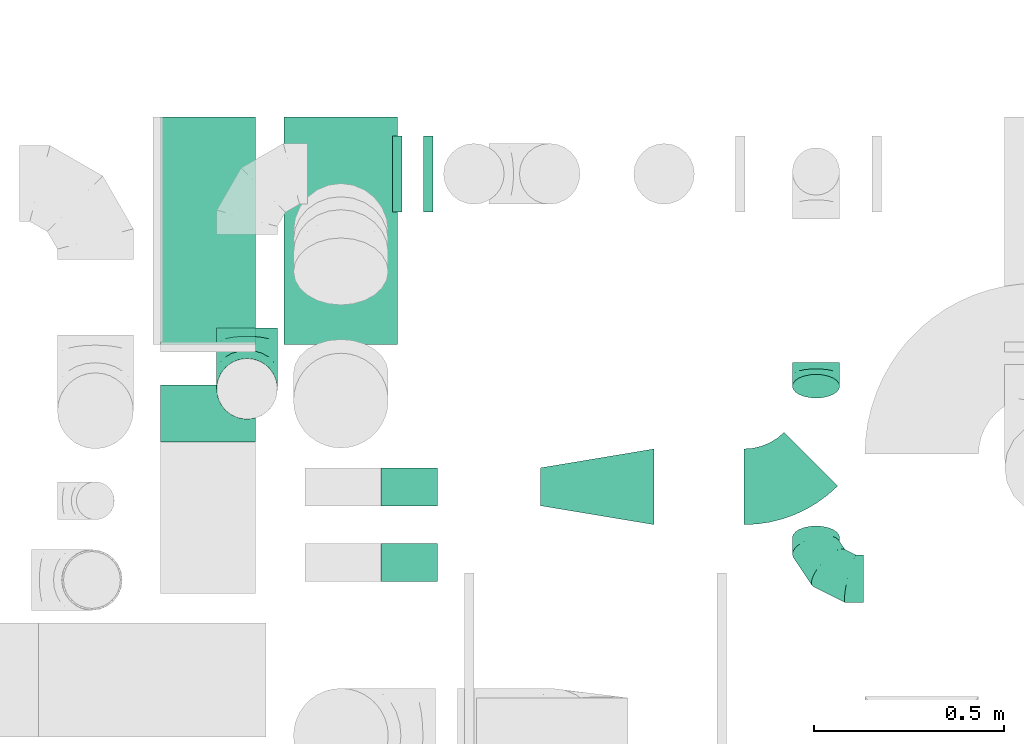
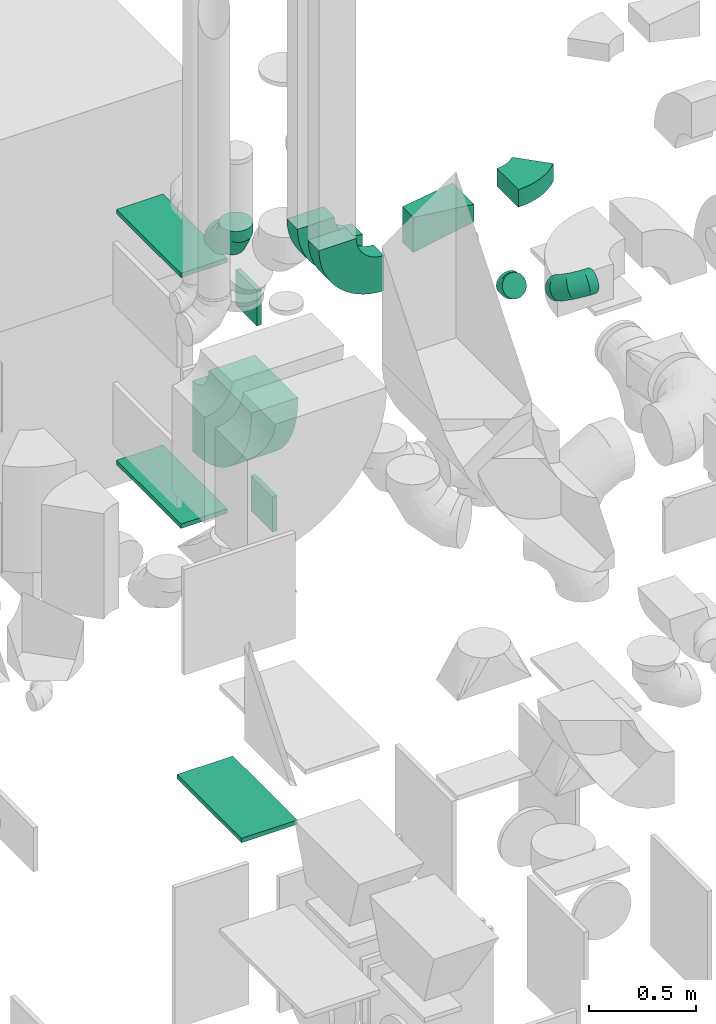
# One storey, part 28 of 59: 13 flow fittings.
"""IFC2X3 building model written with IfcOpenShell, lengths in millimetres."""

from ifc_helpers import new_model, entity, si_unit, converted_unit, derived_unit, direction, frame, frame_2d, origin, origin_2d_with_axis, place, context, subcontext, project, spatial, polyline, circle_curve, parameter, trimmed, segment, composite_curve, rectangle, outline, extrude, faceted_brep, source, transform, mapped, material, type_object, type_shapes, element, save


model = new_model("IFC2X3")

# Units and contexts
model_context = context("Model", 3, precision=0.01, world=origin(), true_north=direction((6.12303176911189e-17, 1.0)))
body_context = subcontext(model_context, "Body", "Model", "MODEL_VIEW")
ifc_project = project(units=[si_unit("LENGTHUNIT", "METRE", prefix="MILLI"), si_unit("AREAUNIT", "SQUARE_METRE"), si_unit("VOLUMEUNIT", "CUBIC_METRE"), converted_unit("PLANEANGLEUNIT", "DEGREE", entity("IfcRatioMeasure", 0.0174532925199433), si_unit("PLANEANGLEUNIT", "RADIAN"), dimensions=[0, 0, 0, 0, 0, 0, 0]), si_unit("MASSUNIT", "GRAM", prefix="KILO"), derived_unit("MASSDENSITYUNIT", [(si_unit("MASSUNIT", "GRAM", prefix="KILO"), 1), (si_unit("LENGTHUNIT", "METRE"), -3)]), derived_unit("MOMENTOFINERTIAUNIT", [(si_unit("LENGTHUNIT", "METRE"), 4)]), si_unit("TIMEUNIT", "SECOND"), si_unit("FREQUENCYUNIT", "HERTZ"), si_unit("THERMODYNAMICTEMPERATUREUNIT", "DEGREE_CELSIUS"), derived_unit("THERMALTRANSMITTANCEUNIT", [(si_unit("MASSUNIT", "GRAM", prefix="KILO"), 1), (si_unit("THERMODYNAMICTEMPERATUREUNIT", "KELVIN"), -1), (si_unit("TIMEUNIT", "SECOND"), -3)]), derived_unit("VOLUMETRICFLOWRATEUNIT", [(si_unit("LENGTHUNIT", "METRE"), 3), (si_unit("TIMEUNIT", "SECOND"), -1)]), derived_unit("MASSFLOWRATEUNIT", [(si_unit("MASSUNIT", "GRAM", prefix="KILO"), 1), (si_unit("TIMEUNIT", "SECOND"), -1)]), derived_unit("ROTATIONALFREQUENCYUNIT", [(si_unit("TIMEUNIT", "SECOND"), -1)]), si_unit("ELECTRICCURRENTUNIT", "AMPERE"), si_unit("ELECTRICVOLTAGEUNIT", "VOLT"), si_unit("POWERUNIT", "WATT"), si_unit("FORCEUNIT", "NEWTON", prefix="KILO"), si_unit("ILLUMINANCEUNIT", "LUX"), si_unit("LUMINOUSFLUXUNIT", "LUMEN"), si_unit("LUMINOUSINTENSITYUNIT", "CANDELA"), derived_unit("USERDEFINED", [(si_unit("MASSUNIT", "GRAM", prefix="KILO"), -1), (si_unit("LENGTHUNIT", "METRE"), -2), (si_unit("TIMEUNIT", "SECOND"), 3), (si_unit("LUMINOUSFLUXUNIT", "LUMEN"), 1)]), derived_unit("LINEARVELOCITYUNIT", [(si_unit("LENGTHUNIT", "METRE"), 1), (si_unit("TIMEUNIT", "SECOND"), -1)]), si_unit("PRESSUREUNIT", "PASCAL"), derived_unit("USERDEFINED", [(si_unit("LENGTHUNIT", "METRE"), -2), (si_unit("MASSUNIT", "GRAM", prefix="KILO"), 1), (si_unit("TIMEUNIT", "SECOND"), -2)]), derived_unit("LINEARFORCEUNIT", [(si_unit("MASSUNIT", "GRAM", prefix="KILO"), 1), (si_unit("LENGTHUNIT", "METRE"), 1), (si_unit("TIMEUNIT", "SECOND"), -2), (si_unit("LENGTHUNIT", "METRE"), -1)]), derived_unit("PLANARFORCEUNIT", [(si_unit("MASSUNIT", "GRAM", prefix="KILO"), 1), (si_unit("LENGTHUNIT", "METRE"), 1), (si_unit("TIMEUNIT", "SECOND"), -2), (si_unit("LENGTHUNIT", "METRE"), -2)])], contexts=[model_context])

# Site, building, storey
site_placement = place(None, origin())
site = spatial("IfcSite", under=ifc_project, at=site_placement, CompositionType="ELEMENT")
building_placement = place(site_placement, origin())
building = spatial("IfcBuilding", under=site, at=building_placement, CompositionType="ELEMENT")
storey_placement = place(building_placement, frame((0.0, 0.0, 28200.0)))
storey = spatial("IfcBuildingStorey", under=building, at=storey_placement, CompositionType="ELEMENT", Elevation=28200.0)

# Flow fittings
ifc_material = material()
duct_fitting_type_1 = type_object("IfcDuctFittingType", PredefinedType="NOTDEFINED", material=ifc_material)
shared_shape_1 = source(origin(), body_context, "Body", "SweptSolid", [
    extrude(rectangle(XDim=24.9999999999999, YDim=600.0, at=origin_2d_with_axis()), frame((12.5, 0.0, -150.0)), (0.0, 0.0, 1.0), 300.0),
])
type_shapes(duct_fitting_type_1, [shared_shape_1])
flow_fitting_1_placement = place(storey_placement, frame((49017.58, 12874.75, 200.0), z_axis=(1.0, 0.0, 0.0), x_axis=(0.0, 0.0, -1.0)))
element("IfcFlowFitting", 1, at=flow_fitting_1_placement, inside=storey, type_object=duct_fitting_type_1, material=ifc_material, context=body_context, shape_type="MappedRepresentation", body=[
    mapped(shared_shape_1, transform((0.0, 0.0, 0.0), scale=1.0)),
])
duct_fitting_type_2 = type_object("IfcDuctFittingType", PredefinedType="NOTDEFINED", material=ifc_material)
shared_shape_2 = source(origin(), body_context, "Body", "SweptSolid", [
    extrude(rectangle(XDim=24.9999999999999, YDim=200.0, at=origin_2d_with_axis()), frame((12.5, 0.0, -100.0)), (0.0, 0.0, 1.0), 200.0),
])
type_shapes(duct_fitting_type_2, [shared_shape_2])
for number, where, z_axis, x_axis in (
    (2, (49260.78, 13024.99, 1699.32), (0.0, 0.0, 1.0), (-1.0, 0.0, 0.0)),
    (3, (49178.28, 13024.99, 2899.32), (0.0, 0.0, 1.0), (-1.0, 0.0, 0.0)),
):
    element("IfcFlowFitting", number, at=place(storey_placement, frame(where, z_axis=z_axis, x_axis=x_axis)), inside=storey, type_object=duct_fitting_type_2, material=ifc_material, context=body_context, shape_type="MappedRepresentation", body=[
        mapped(shared_shape_2, transform((0.0, 0.0, 0.0), scale=1.0)),
    ])
duct_fitting_type_3 = type_object("IfcDuctFittingType", PredefinedType="NOTDEFINED", material=ifc_material)
shared_shape_3 = source(origin(), body_context, "Body", "SweptSolid", [
    extrude(rectangle(XDim=24.9999999999999, YDim=600.0, at=origin_2d_with_axis()), frame((12.5, 0.0, -125.0)), (0.0, 0.0, 1.0), 250.0),
])
type_shapes(duct_fitting_type_3, [shared_shape_3])
for number, where, z_axis, x_axis in (
    (4, (48667.04, 12874.75, 2100.0), (1.0, 0.0, 0.0), (0.0, 0.0, -1.0)),
    (5, (48667.04, 12874.75, 3500.0), (1.0, 0.0, 0.0), (0.0, 0.0, 1.0)),
):
    element("IfcFlowFitting", number, at=place(storey_placement, frame(where, z_axis=z_axis, x_axis=x_axis)), inside=storey, type_object=duct_fitting_type_3, material=ifc_material, context=body_context, shape_type="MappedRepresentation", body=[
        mapped(shared_shape_3, transform((0.0, 0.0, 0.0), scale=1.0)),
    ])
duct_fitting_type_4 = type_object("IfcDuctFittingType", PredefinedType="NOTDEFINED", material=ifc_material)
shared_shape_4 = source(origin(), body_context, "Body", "Brep", [
    faceted_brep([(-160.0, 0.0, -80.0), (-160.0, -20.71, -77.27), (-160.0, -40.0, -69.28), (-160.0, -56.57, -56.57), (-160.0, -69.28, -40.0), (-160.0, -77.27, -20.71), (-160.0, -80.0, 0.0), (-160.0, -77.27, 20.71), (-160.0, -69.28, 40.0), (-160.0, -56.57, 56.57), (-160.0, -40.0, 69.28), (-160.0, -20.71, 77.27), (-160.0, 0.0, 80.0), (-160.0, 20.71, 77.27), (-160.0, 40.0, 69.28), (-160.0, 56.57, 56.57), (-160.0, 69.28, 40.0), (-160.0, 77.27, 20.71), (-160.0, 80.0, 0.0), (-160.0, 77.27, -20.71), (-160.0, 69.28, -40.0), (-160.0, 56.57, -56.57), (-160.0, 40.0, -69.28), (-160.0, 20.71, -77.27), (-122.68, 20.71, 77.27), (-127.85, 40.0, 69.28), (-117.13, 0.0, 80.0), (-132.29, 56.57, 56.57), (-137.83, 77.27, 20.71), (-138.56, 80.0, 0.0), (-135.69, 69.28, 40.0), (-135.69, 69.28, -40.0), (-132.29, 56.57, -56.57), (-137.83, 77.27, -20.71), (-122.68, 20.71, -77.27), (-117.13, 0.0, -80.0), (-127.85, 40.0, -69.28), (-111.58, -20.71, -77.27), (-106.41, -40.0, -69.28), (-101.97, -56.57, -56.57), (-98.56, -69.28, -40.0), (-96.42, -77.27, -20.71), (-95.69, -80.0, 0.0), (-96.42, -77.27, 20.71), (-98.56, -69.28, 40.0), (-101.97, -56.57, 56.57), (-106.41, -40.0, 69.28), (-111.58, -20.71, 77.27), (-58.03, 58.03, 77.27), (-72.15, 72.15, 69.28), (-42.87, 42.87, 80.0), (-84.28, 84.28, 56.57), (-93.59, 93.59, 40.0), (-99.44, 99.44, 20.71), (-101.44, 101.44, 0.0), (-99.44, 99.44, -20.71), (-93.59, 93.59, -40.0), (-84.28, 84.28, -56.57), (-58.03, 58.03, -77.27), (-42.87, 42.87, -80.0), (-72.15, 72.15, -69.28), (-27.71, 27.71, -77.27), (-13.59, 13.59, -69.28), (-1.46, 1.46, -56.57), (7.85, -7.85, -40.0), (13.7, -13.7, -20.71), (15.69, -15.69, 0.0), (13.7, -13.7, 20.71), (7.85, -7.85, 40.0), (-1.46, 1.46, 56.57), (-13.59, 13.59, 69.28), (-27.71, 27.71, 77.27), (-20.71, 122.68, 77.27), (-40.0, 127.85, 69.28), (0.0, 117.13, 80.0), (-56.57, 132.29, 56.57), (-69.28, 135.69, 40.0), (-77.27, 137.83, 20.71), (-80.0, 138.56, 0.0), (-77.27, 137.83, -20.71), (-69.28, 135.69, -40.0), (-56.57, 132.29, -56.57), (-20.71, 122.68, -77.27), (0.0, 117.13, -80.0), (-40.0, 127.85, -69.28), (20.71, 111.58, -77.27), (40.0, 106.41, -69.28), (56.57, 101.97, -56.57), (69.28, 98.56, -40.0), (77.27, 96.42, -20.71), (80.0, 95.69, 0.0), (77.27, 96.42, 20.71), (69.28, 98.56, 40.0), (56.57, 101.97, 56.57), (40.0, 106.41, 69.28), (20.71, 111.58, 77.27), (-20.71, 160.0, -77.27), (-40.0, 160.0, -69.28), (-56.57, 160.0, -56.57), (-69.28, 160.0, -40.0), (-77.27, 160.0, -20.71), (-80.0, 160.0, 0.0), (-77.27, 160.0, 20.71), (-69.28, 160.0, 40.0), (-56.57, 160.0, 56.57), (-40.0, 160.0, 69.28), (-20.71, 160.0, 77.27), (0.0, 160.0, 80.0), (20.71, 160.0, 77.27), (40.0, 160.0, 69.28), (56.57, 160.0, 56.57), (69.28, 160.0, 40.0), (77.27, 160.0, 20.71), (80.0, 160.0, 0.0), (77.27, 160.0, -20.71), (69.28, 160.0, -40.0), (56.57, 160.0, -56.57), (40.0, 160.0, -69.28), (20.71, 160.0, -77.27), (0.0, 160.0, -80.0)], [[[0, 1, 2, 3, 4, 5, 6, 7, 8, 9, 10, 11, 12, 13, 14, 15, 16, 17, 18, 19, 20, 21, 22, 23]], [[24, 25, 14, 13]], [[26, 24, 13, 12]], [[14, 25, 27, 15]], [[28, 29, 18, 17]], [[30, 28, 17, 16]], [[15, 27, 30, 16]], [[20, 31, 32, 21]], [[33, 31, 20, 19]], [[18, 29, 33, 19]], [[34, 35, 0, 23]], [[36, 34, 23, 22]], [[32, 36, 22, 21]], [[1, 0, 35, 37]], [[2, 1, 37, 38]], [[3, 2, 38, 39]], [[5, 4, 40, 41]], [[6, 5, 41, 42]], [[39, 40, 4, 3]], [[6, 42, 43, 7]], [[7, 43, 44, 8]], [[8, 44, 45, 9]], [[9, 45, 46, 10]], [[10, 46, 47, 11]], [[26, 12, 11, 47]], [[48, 49, 25, 24]], [[50, 48, 24, 26]], [[27, 25, 49, 51]], [[52, 53, 28, 30]], [[51, 52, 30, 27]], [[29, 28, 53, 54]], [[55, 56, 31, 33]], [[54, 55, 33, 29]], [[32, 31, 56, 57]], [[58, 59, 35, 34]], [[60, 58, 34, 36]], [[57, 60, 36, 32]], [[37, 35, 59, 61]], [[38, 37, 61, 62]], [[39, 38, 62, 63]], [[41, 40, 64, 65]], [[42, 41, 65, 66]], [[63, 64, 40, 39]], [[43, 42, 66, 67]], [[44, 43, 67, 68]], [[68, 69, 45, 44]], [[46, 45, 69, 70]], [[47, 46, 70, 71]], [[26, 47, 71, 50]], [[72, 73, 49, 48]], [[74, 72, 48, 50]], [[51, 49, 73, 75]], [[76, 77, 53, 52]], [[75, 76, 52, 51]], [[54, 53, 77, 78]], [[79, 80, 56, 55]], [[78, 79, 55, 54]], [[57, 56, 80, 81]], [[82, 83, 59, 58]], [[84, 82, 58, 60]], [[81, 84, 60, 57]], [[61, 59, 83, 85]], [[62, 61, 85, 86]], [[63, 62, 86, 87]], [[65, 64, 88, 89]], [[66, 65, 89, 90]], [[87, 88, 64, 63]], [[67, 66, 90, 91]], [[68, 67, 91, 92]], [[92, 93, 69, 68]], [[70, 69, 93, 94]], [[71, 70, 94, 95]], [[50, 71, 95, 74]], [[96, 97, 98, 99, 100, 101, 102, 103, 104, 105, 106, 107, 108, 109, 110, 111, 112, 113, 114, 115, 116, 117, 118, 119]], [[72, 74, 107, 106]], [[73, 72, 106, 105]], [[75, 73, 105, 104]], [[77, 76, 103, 102]], [[78, 77, 102, 101]], [[75, 104, 103, 76]], [[78, 101, 100, 79]], [[79, 100, 99, 80]], [[80, 99, 98, 81]], [[84, 97, 96, 82]], [[82, 96, 119, 83]], [[84, 81, 98, 97]], [[118, 117, 86, 85]], [[119, 118, 85, 83]], [[116, 87, 86, 117]], [[88, 115, 114, 89]], [[89, 114, 113, 90]], [[115, 88, 87, 116]], [[112, 111, 92, 91]], [[113, 112, 91, 90]], [[111, 110, 93, 92]], [[95, 94, 109, 108]], [[74, 95, 108, 107]], [[110, 109, 94, 93]]]),
])
type_shapes(duct_fitting_type_4, [shared_shape_4])
flow_fitting_2_placement = place(storey_placement, frame((48770.09, 12457.98, 3650.0), z_axis=(1.0, 0.0, 0.0), x_axis=(0.0, 0.0, -1.0)))
element("IfcFlowFitting", 6, at=flow_fitting_2_placement, inside=storey, type_object=duct_fitting_type_4, material=ifc_material, context=body_context, shape_type="MappedRepresentation", body=[
    mapped(shared_shape_4, transform((0.0, 0.0, 0.0), scale=1.0)),
])
duct_fitting_type_5 = type_object("IfcDuctFittingType", PredefinedType="NOTDEFINED", material=ifc_material)
shared_shape_5 = source(origin(), body_context, "Body", "Brep", [
    faceted_brep([(-125.0, 0.0, -62.5), (-125.0, -16.18, -60.37), (-125.0, -31.25, -54.13), (-125.0, -44.19, -44.19), (-125.0, -54.13, -31.25), (-125.0, -60.37, -16.18), (-125.0, -62.5, 0.0), (-125.0, -60.37, 16.18), (-125.0, -54.13, 31.25), (-125.0, -44.19, 44.19), (-125.0, -31.25, 54.13), (-125.0, -16.18, 60.37), (-125.0, 0.0, 62.5), (-125.0, 16.18, 60.37), (-125.0, 31.25, 54.13), (-125.0, 44.19, 44.19), (-125.0, 54.13, 31.25), (-125.0, 60.37, 16.18), (-125.0, 62.5, 0.0), (-125.0, 60.37, -16.18), (-125.0, 54.13, -31.25), (-125.0, 44.19, -44.19), (-125.0, 31.25, -54.13), (-125.0, 16.18, -60.37), (-95.84, 16.18, 60.37), (-99.88, 31.25, 54.13), (-91.51, 0.0, 62.5), (-103.35, 44.19, 44.19), (-107.68, 60.37, 16.18), (-108.25, 62.5, 0.0), (-106.01, 54.13, 31.25), (-106.01, 54.13, -31.25), (-103.35, 44.19, -44.19), (-107.68, 60.37, -16.18), (-95.84, 16.18, -60.37), (-91.51, 0.0, -62.5), (-99.88, 31.25, -54.13), (-87.17, -16.18, -60.37), (-83.13, -31.25, -54.13), (-79.66, -44.19, -44.19), (-77.0, -54.13, -31.25), (-75.33, -60.37, -16.18), (-74.76, -62.5, 0.0), (-75.33, -60.37, 16.18), (-77.0, -54.13, 31.25), (-79.66, -44.19, 44.19), (-83.13, -31.25, 54.13), (-87.17, -16.18, 60.37), (-45.34, 45.34, 60.37), (-56.37, 56.37, 54.13), (-33.49, 33.49, 62.5), (-65.85, 65.85, 44.19), (-73.12, 73.12, 31.25), (-77.69, 77.69, 16.18), (-79.25, 79.25, 0.0), (-77.69, 77.69, -16.18), (-73.12, 73.12, -31.25), (-65.85, 65.85, -44.19), (-45.34, 45.34, -60.37), (-33.49, 33.49, -62.5), (-56.37, 56.37, -54.13), (-21.65, 21.65, -60.37), (-10.62, 10.62, -54.13), (-1.14, 1.14, -44.19), (6.13, -6.13, -31.25), (10.7, -10.7, -16.18), (12.26, -12.26, 0.0), (10.7, -10.7, 16.18), (6.13, -6.13, 31.25), (-1.14, 1.14, 44.19), (-10.62, 10.62, 54.13), (-21.65, 21.65, 60.37), (-16.18, 95.84, 60.37), (-31.25, 99.88, 54.13), (0.0, 91.51, 62.5), (-44.19, 103.35, 44.19), (-54.13, 106.01, 31.25), (-60.37, 107.68, 16.18), (-62.5, 108.25, 0.0), (-60.37, 107.68, -16.18), (-54.13, 106.01, -31.25), (-44.19, 103.35, -44.19), (-16.18, 95.84, -60.37), (0.0, 91.51, -62.5), (-31.25, 99.88, -54.13), (16.18, 87.17, -60.37), (31.25, 83.13, -54.13), (44.19, 79.66, -44.19), (54.13, 77.0, -31.25), (60.37, 75.33, -16.18), (62.5, 74.76, 0.0), (60.37, 75.33, 16.18), (54.13, 77.0, 31.25), (44.19, 79.66, 44.19), (31.25, 83.13, 54.13), (16.18, 87.17, 60.37), (-16.18, 125.0, -60.37), (-31.25, 125.0, -54.13), (-44.19, 125.0, -44.19), (-54.13, 125.0, -31.25), (-60.37, 125.0, -16.18), (-62.5, 125.0, 0.0), (-60.37, 125.0, 16.18), (-54.13, 125.0, 31.25), (-44.19, 125.0, 44.19), (-31.25, 125.0, 54.13), (-16.18, 125.0, 60.37), (0.0, 125.0, 62.5), (16.18, 125.0, 60.37), (31.25, 125.0, 54.13), (44.19, 125.0, 44.19), (54.13, 125.0, 31.25), (60.37, 125.0, 16.18), (62.5, 125.0, 0.0), (60.37, 125.0, -16.18), (54.13, 125.0, -31.25), (44.19, 125.0, -44.19), (31.25, 125.0, -54.13), (16.18, 125.0, -60.37), (0.0, 125.0, -62.5)], [[[0, 1, 2, 3, 4, 5, 6, 7, 8, 9, 10, 11, 12, 13, 14, 15, 16, 17, 18, 19, 20, 21, 22, 23]], [[24, 25, 14, 13]], [[26, 24, 13, 12]], [[14, 25, 27, 15]], [[28, 29, 18, 17]], [[30, 28, 17, 16]], [[15, 27, 30, 16]], [[20, 31, 32, 21]], [[33, 31, 20, 19]], [[18, 29, 33, 19]], [[34, 35, 0, 23]], [[36, 34, 23, 22]], [[21, 32, 36, 22]], [[1, 0, 35, 37]], [[2, 1, 37, 38]], [[38, 39, 3, 2]], [[5, 4, 40, 41]], [[6, 5, 41, 42]], [[39, 40, 4, 3]], [[6, 42, 43, 7]], [[7, 43, 44, 8]], [[45, 9, 8, 44]], [[9, 45, 46, 10]], [[10, 46, 47, 11]], [[26, 12, 11, 47]], [[48, 49, 25, 24]], [[50, 48, 24, 26]], [[27, 25, 49, 51]], [[52, 53, 28, 30]], [[51, 52, 30, 27]], [[29, 28, 53, 54]], [[55, 56, 31, 33]], [[54, 55, 33, 29]], [[57, 32, 31, 56]], [[58, 59, 35, 34]], [[60, 58, 34, 36]], [[57, 60, 36, 32]], [[37, 35, 59, 61]], [[38, 37, 61, 62]], [[39, 38, 62, 63]], [[41, 40, 64, 65]], [[42, 41, 65, 66]], [[63, 64, 40, 39]], [[43, 42, 66, 67]], [[44, 43, 67, 68]], [[68, 69, 45, 44]], [[46, 45, 69, 70]], [[47, 46, 70, 71]], [[26, 47, 71, 50]], [[72, 73, 49, 48]], [[74, 72, 48, 50]], [[51, 49, 73, 75]], [[76, 77, 53, 52]], [[75, 76, 52, 51]], [[54, 53, 77, 78]], [[79, 80, 56, 55]], [[78, 79, 55, 54]], [[81, 57, 56, 80]], [[82, 83, 59, 58]], [[84, 82, 58, 60]], [[81, 84, 60, 57]], [[61, 59, 83, 85]], [[62, 61, 85, 86]], [[63, 62, 86, 87]], [[65, 64, 88, 89]], [[66, 65, 89, 90]], [[87, 88, 64, 63]], [[67, 66, 90, 91]], [[68, 67, 91, 92]], [[92, 93, 69, 68]], [[70, 69, 93, 94]], [[71, 70, 94, 95]], [[50, 71, 95, 74]], [[96, 97, 98, 99, 100, 101, 102, 103, 104, 105, 106, 107, 108, 109, 110, 111, 112, 113, 114, 115, 116, 117, 118, 119]], [[72, 74, 107, 106]], [[73, 72, 106, 105]], [[75, 73, 105, 104]], [[77, 76, 103, 102]], [[78, 77, 102, 101]], [[75, 104, 103, 76]], [[78, 101, 100, 79]], [[79, 100, 99, 80]], [[80, 99, 98, 81]], [[96, 119, 83, 82]], [[97, 96, 82, 84]], [[84, 81, 98, 97]], [[83, 119, 118, 85]], [[85, 118, 117, 86]], [[116, 87, 86, 117]], [[88, 115, 114, 89]], [[89, 114, 113, 90]], [[115, 88, 87, 116]], [[91, 90, 113, 112]], [[92, 91, 112, 111]], [[111, 110, 93, 92]], [[95, 94, 109, 108]], [[74, 95, 108, 107]], [[110, 109, 94, 93]]]),
])
type_shapes(duct_fitting_type_5, [shared_shape_5])
flow_fitting_3_placement = place(storey_placement, frame((50271.02, 11956.82, 3210.0), z_axis=(0.0, 0.499999999999997, 0.86602540378444), x_axis=(0.0, -0.86602540378444, 0.499999999999997)))
element("IfcFlowFitting", 7, at=flow_fitting_3_placement, inside=storey, type_object=duct_fitting_type_5, material=ifc_material, context=body_context, shape_type="MappedRepresentation", body=[
    mapped(shared_shape_5, transform((0.0, 0.0, 0.0), scale=1.0)),
])
duct_fitting_type_6 = type_object("IfcDuctFittingType", PredefinedType="NOTDEFINED", material=ifc_material)
shared_shape_6 = source(origin(), body_context, "Body", "Brep", [
    faceted_brep([(-33.49, 0.0, -62.5), (-33.49, -16.18, -60.37), (-33.49, -31.25, -54.13), (-33.49, -44.19, -44.19), (-33.49, -54.13, -31.25), (-33.49, -60.37, -16.18), (-33.49, -62.5, 0.0), (-33.49, -60.37, 16.18), (-33.49, -54.13, 31.25), (-33.49, -44.19, 44.19), (-33.49, -31.25, 54.13), (-33.49, -16.18, 60.37), (-33.49, 0.0, 62.5), (-33.49, 16.18, 60.37), (-33.49, 31.25, 54.13), (-33.49, 44.19, 44.19), (-33.49, 54.13, 31.25), (-33.49, 60.37, 16.18), (-33.49, 62.5, 0.0), (-33.49, 60.37, -16.18), (-33.49, 54.13, -31.25), (-33.49, 44.19, -44.19), (-33.49, 31.25, -54.13), (-33.49, 16.18, -60.37), (-4.33, 16.18, 60.37), (-8.37, 31.25, 54.13), (0.0, 0.0, 62.5), (-11.84, 44.19, 44.19), (-16.18, 60.37, 16.18), (-16.75, 62.5, 0.0), (-14.5, 54.13, 31.25), (-14.5, 54.13, -31.25), (-11.84, 44.19, -44.19), (-16.18, 60.37, -16.18), (-4.33, 16.18, -60.37), (0.0, 0.0, -62.5), (-8.37, 31.25, -54.13), (4.33, -16.18, -60.37), (8.37, -31.25, -54.13), (11.84, -44.19, -44.19), (14.5, -54.13, -31.25), (16.18, -60.37, -16.18), (16.75, -62.5, 0.0), (16.18, -60.37, 16.18), (14.5, -54.13, 31.25), (11.84, -44.19, 44.19), (8.37, -31.25, 54.13), (4.33, -16.18, 60.37), (29.01, 16.75, 62.5), (20.92, 30.76, 60.37), (13.38, 43.81, 54.13), (6.91, 55.02, 44.19), (1.94, 63.62, 31.25), (-1.18, 69.03, 16.18), (-2.24, 70.87, 0.0), (-1.18, 69.03, -16.18), (1.94, 63.62, -31.25), (6.91, 55.02, -44.19), (20.92, 30.76, -60.37), (29.01, 16.75, -62.5), (13.38, 43.81, -54.13), (37.09, 2.74, -60.37), (44.63, -10.32, -54.13), (51.1, -21.53, -44.19), (56.07, -30.13, -31.25), (59.19, -35.54, -16.18), (60.26, -37.38, 0.0), (59.19, -35.54, 16.18), (56.07, -30.13, 31.25), (51.1, -21.53, 44.19), (44.63, -10.32, 54.13), (37.09, 2.74, 60.37)], [[[0, 1, 2, 3, 4, 5, 6, 7, 8, 9, 10, 11, 12, 13, 14, 15, 16, 17, 18, 19, 20, 21, 22, 23]], [[24, 25, 14, 13]], [[26, 24, 13, 12]], [[14, 25, 27, 15]], [[28, 29, 18, 17]], [[30, 28, 17, 16]], [[15, 27, 30, 16]], [[20, 31, 32, 21]], [[33, 31, 20, 19]], [[18, 29, 33, 19]], [[34, 35, 0, 23]], [[36, 34, 23, 22]], [[21, 32, 36, 22]], [[1, 0, 35, 37]], [[2, 1, 37, 38]], [[38, 39, 3, 2]], [[5, 4, 40, 41]], [[6, 5, 41, 42]], [[39, 40, 4, 3]], [[6, 42, 43, 7]], [[7, 43, 44, 8]], [[45, 9, 8, 44]], [[9, 45, 46, 10]], [[10, 46, 47, 11]], [[26, 12, 11, 47]], [[24, 26, 48, 49]], [[25, 24, 49, 50]], [[27, 25, 50, 51]], [[28, 30, 52, 53]], [[29, 28, 53, 54]], [[27, 51, 52, 30]], [[29, 54, 55, 33]], [[33, 55, 56, 31]], [[31, 56, 57, 32]], [[58, 59, 35, 34]], [[60, 58, 34, 36]], [[36, 32, 57, 60]], [[35, 59, 61, 37]], [[37, 61, 62, 38]], [[63, 39, 38, 62]], [[40, 64, 65, 41]], [[41, 65, 66, 42]], [[64, 40, 39, 63]], [[43, 42, 66, 67]], [[44, 43, 67, 68]], [[68, 69, 45, 44]], [[47, 46, 70, 71]], [[26, 47, 71, 48]], [[69, 70, 46, 45]], [[58, 60, 57, 56, 55, 54, 53, 52, 51, 50, 49, 48, 71, 70, 69, 68, 67, 66, 65, 64, 63, 62, 61, 59]]]),
])
type_shapes(duct_fitting_type_6, [shared_shape_6])
flow_fitting_4_placement = place(storey_placement, frame((50271.02, 12493.76, 2900.0), z_axis=(1.0, 0.0, 0.0), x_axis=(0.0, 0.866025403784456, -0.49999999999997)))
element("IfcFlowFitting", 8, at=flow_fitting_4_placement, inside=storey, type_object=duct_fitting_type_6, material=ifc_material, context=body_context, shape_type="MappedRepresentation", body=[
    mapped(shared_shape_6, transform((0.0, 0.0, 0.0), scale=1.0)),
])
duct_fitting_type_7 = type_object("IfcDuctFittingType", PredefinedType="NOTDEFINED", material=ifc_material)
shared_shape_7 = source(origin(), body_context, "Body", "Brep", [
    faceted_brep([(300.0, -50.0, 50.0), (300.0, -50.0, -150.0), (300.0, 50.0, -150.0), (300.0, 50.0, 50.0), (0.0, -100.0, 50.0), (0.0, 100.0, 50.0), (0.0, 100.0, -50.0), (0.0, -100.0, -50.0)], [[[0, 1, 2, 3]], [[4, 5, 6, 7]], [[4, 7, 1, 0]], [[7, 6, 2, 1]], [[6, 5, 3, 2]], [[5, 4, 0, 3]]]),
])
type_shapes(duct_fitting_type_7, [shared_shape_7])
flow_fitting_5_placement = place(storey_placement, frame((49844.03, 12199.48, 3700.0), z_axis=(1.02183148170489e-08, 0.0, 1.0), x_axis=(-1.0, 0.0, 1.02183148170489e-08)))
element("IfcFlowFitting", 9, at=flow_fitting_5_placement, inside=storey, type_object=duct_fitting_type_7, material=ifc_material, context=body_context, shape_type="MappedRepresentation", body=[
    mapped(shared_shape_7, transform((0.0, 0.0, 0.0), scale=1.0)),
])
duct_fitting_type_8 = type_object("IfcDuctFittingType", PredefinedType="NOTDEFINED", material=ifc_material)
shared_shape_8 = source(origin(), body_context, "Body", "SweptSolid", [
    extrude(outline(composite_curve([segment(polyline([(-225.0, -125.0), (-25.0, -125.0)]), True, "CONTINUOUS"), segment(trimmed(circle_curve(frame_2d((125.0, -125.0), x_axis=(0.0, 1.0)), 150.0), [parameter(0.0)], [parameter(90.0000000000001)], True, "PARAMETER"), False, "CONTINUOUS"), segment(polyline([(125.0, 25.0), (125.0, 225.0)]), True, "CONTINUOUS"), segment(trimmed(circle_curve(frame_2d((125.0, -125.0), x_axis=(0.0, 1.0)), 350.0), [parameter(0.0)], [parameter(90.0000000000001)], True, "PARAMETER"), True, "CONTINUOUS")], self_intersect=False)), frame((-125.0, 125.0, -50.0), z_axis=(0.0, 0.0, 1.0), x_axis=(-1.0, 0.0, 0.0)), (0.0, 0.0, 1.0), 100.0),
])
type_shapes(duct_fitting_type_8, [shared_shape_8])
flow_fitting_6_placement = place(storey_placement, frame((49023.0, 12199.48, 3650.0), z_axis=(0.0, -1.0, 0.0), x_axis=(0.0, 0.0, -1.0)))
element("IfcFlowFitting", 10, at=flow_fitting_6_placement, inside=storey, type_object=duct_fitting_type_8, material=ifc_material, context=body_context, shape_type="MappedRepresentation", body=[
    mapped(shared_shape_8, transform((0.0, 0.0, 0.0), scale=1.0)),
])
duct_fitting_type_9 = type_object("IfcDuctFittingType", PredefinedType="NOTDEFINED", material=ifc_material)
shared_shape_9 = source(origin(), body_context, "Body", "SweptSolid", [
    extrude(outline(composite_curve([segment(polyline([(-136.61, -88.39), (63.39, -88.39)]), True, "CONTINUOUS"), segment(trimmed(circle_curve(frame_2d((213.39, -88.39), x_axis=(-0.707106781186546, 0.707106781186546)), 150.0), [parameter(0.0)], [parameter(45.0)], True, "PARAMETER"), False, "CONTINUOUS"), segment(polyline([(107.32, 17.68), (-34.1, 159.1)]), True, "CONTINUOUS"), segment(trimmed(circle_curve(frame_2d((213.39, -88.39), x_axis=(-0.707106781186546, 0.707106781186546)), 350.0), [parameter(0.0)], [parameter(45.0)], True, "PARAMETER"), True, "CONTINUOUS")], self_intersect=False)), frame((-15.17, 36.61, -50.0), z_axis=(0.0, 0.0, 1.0), x_axis=(-0.707106781186547, 0.707106781186548, 0.0)), (0.0, 0.0, 1.0), 100.0),
])
type_shapes(duct_fitting_type_9, [shared_shape_9])
flow_fitting_7_placement = place(storey_placement, frame((50184.61, 12199.48, 3700.0)))
element("IfcFlowFitting", 11, at=flow_fitting_7_placement, inside=storey, type_object=duct_fitting_type_9, material=ifc_material, context=body_context, shape_type="MappedRepresentation", body=[
    mapped(shared_shape_9, transform((0.0, 0.0, 0.0), scale=1.0)),
])
duct_fitting_type_10 = type_object("IfcDuctFittingType", PredefinedType="NOTDEFINED", material=ifc_material)
shared_shape_10 = source(origin(), body_context, "Body", "SweptSolid", [
    extrude(outline(composite_curve([segment(polyline([(-375.0, -175.0), (25.0, -175.0)]), True, "CONTINUOUS"), segment(trimmed(circle_curve(frame_2d((175.0, -175.0), x_axis=(0.0, 1.0)), 150.0), [parameter(0.0)], [parameter(90.0000000000001)], True, "PARAMETER"), False, "CONTINUOUS"), segment(polyline([(175.0, -25.0), (175.0, 375.0)]), True, "CONTINUOUS"), segment(trimmed(circle_curve(frame_2d((175.0, -175.0), x_axis=(0.0, 1.0)), 550.0), [parameter(0.0)], [parameter(90.0)], True, "PARAMETER"), True, "CONTINUOUS")], self_intersect=False)), frame((-175.0, 175.0, -125.0), z_axis=(0.0, 0.0, 1.0), x_axis=(-1.0, 0.0, 0.0)), (0.0, 0.0, 1.0), 250.0),
])
type_shapes(duct_fitting_type_10, [shared_shape_10])
flow_fitting_8_placement = place(storey_placement, frame((48667.04, 12117.5, 2780.0), z_axis=(-1.0, 0.0, 0.0), x_axis=(0.0, -1.0, 0.0)))
element("IfcFlowFitting", 12, at=flow_fitting_8_placement, inside=storey, type_object=duct_fitting_type_10, material=ifc_material, context=body_context, shape_type="MappedRepresentation", body=[
    mapped(shared_shape_10, transform((0.0, 0.0, 0.0), scale=1.0)),
])
duct_fitting_type_11 = type_object("IfcDuctFittingType", PredefinedType="NOTDEFINED", material=ifc_material)
shared_shape_11 = source(origin(), body_context, "Body", "SweptSolid", [
    extrude(outline(composite_curve([segment(polyline([(-225.0, -125.0), (-25.0, -125.0)]), True, "CONTINUOUS"), segment(trimmed(circle_curve(frame_2d((125.0, -125.0), x_axis=(1.03774482340668e-08, 1.0)), 150.0), [parameter(0.0)], [parameter(90.0000005945839)], True, "PARAMETER"), False, "CONTINUOUS"), segment(polyline([(125.0, 25.0), (125.0, 225.0)]), True, "CONTINUOUS"), segment(trimmed(circle_curve(frame_2d((125.0, -125.0), x_axis=(1.03774482340668e-08, 1.0)), 350.0), [parameter(0.0)], [parameter(90.0000005945839)], True, "PARAMETER"), True, "CONTINUOUS")], self_intersect=False)), frame((-125.0, 125.0, -50.0), z_axis=(0.0, 0.0, 1.0), x_axis=(-1.0, -1.0377445636145e-08, 0.0)), (0.0, 0.0, 1.0), 100.0),
])
type_shapes(duct_fitting_type_11, [shared_shape_11])
flow_fitting_9_placement = place(storey_placement, frame((49023.0, 11999.48, 3650.0), z_axis=(0.0, 1.0, 0.0), x_axis=(-1.0, 0.0, -1.03774455713322e-08)))
element("IfcFlowFitting", 13, at=flow_fitting_9_placement, inside=storey, type_object=duct_fitting_type_11, material=ifc_material, context=body_context, shape_type="MappedRepresentation", body=[
    mapped(shared_shape_11, transform((0.0, 0.0, 0.0), scale=1.0)),
])

save(model, "model.ifc")
